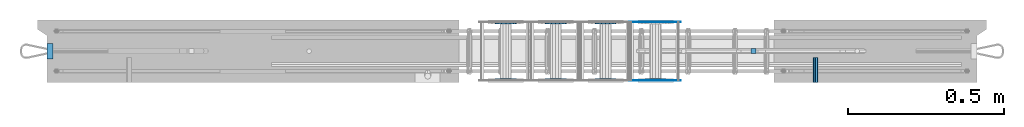
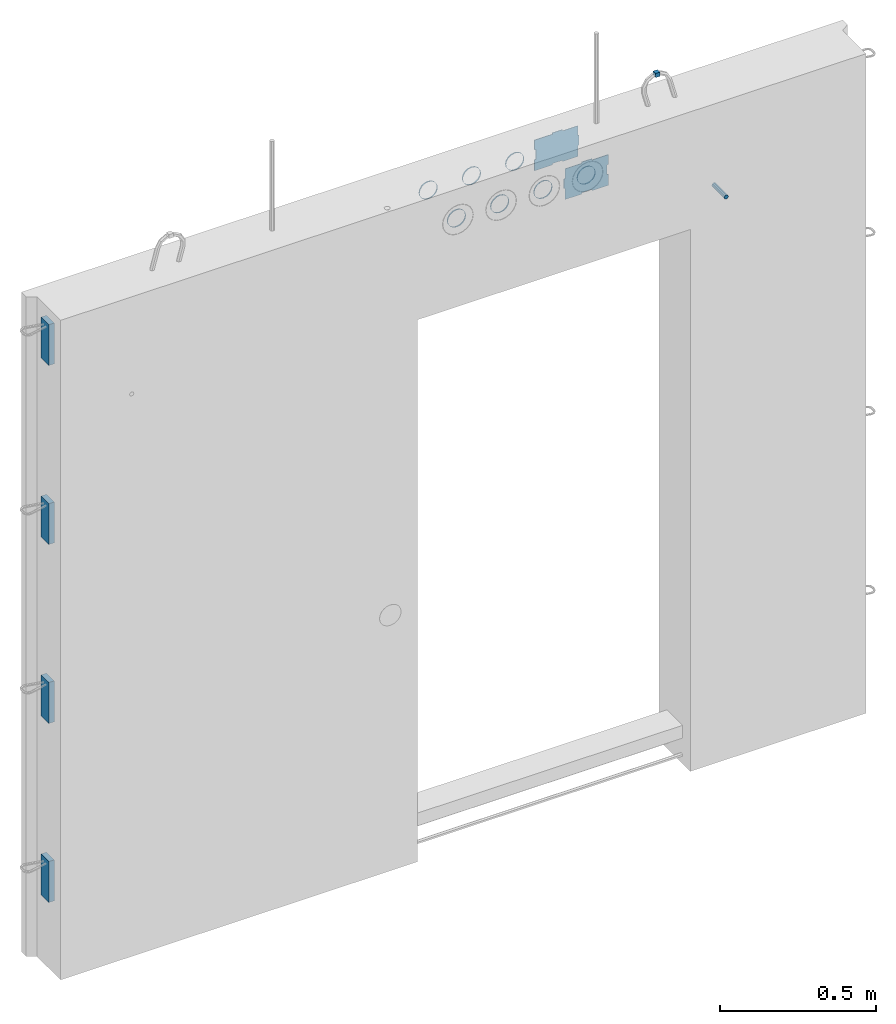
# One storey, part 5 of 11: 9 beams, 6 plates.
"""IFC2X3 building model written with IfcOpenShell, lengths in millimetres."""

from ifc_helpers import new_model, si_unit, frame, origin_with_axes, place, context, subcontext, project, spatial, faceted_brep, material, type_object, element, save


model = new_model("IFC2X3")

# Units and contexts
model_context = context("Model", 3, precision=1e-05, world=origin_with_axes())
body_context = subcontext(model_context, "Body", "Model", "MODEL_VIEW")
ifc_project = project(units=[si_unit("LENGTHUNIT", "METRE", prefix="MILLI"), si_unit("AREAUNIT", "SQUARE_METRE"), si_unit("VOLUMEUNIT", "CUBIC_METRE"), si_unit("MASSUNIT", "GRAM", prefix="KILO"), si_unit("TIMEUNIT", "SECOND"), si_unit("PLANEANGLEUNIT", "RADIAN"), si_unit("SOLIDANGLEUNIT", "STERADIAN"), si_unit("THERMODYNAMICTEMPERATUREUNIT", "DEGREE_CELSIUS"), si_unit("LUMINOUSINTENSITYUNIT", "LUMEN")], contexts=[model_context])

# Site, building, storey
site_placement = place(None, origin_with_axes())
site = spatial("IfcSite", under=ifc_project, at=site_placement, CompositionType="ELEMENT")
building_placement = place(site_placement, origin_with_axes())
building = spatial("IfcBuilding", under=site, at=building_placement, Name="Undefined", CompositionType="ELEMENT")
storey_placement = place(building_placement, origin_with_axes())
storey = spatial("IfcBuildingStorey", under=building, at=storey_placement, Name="Undefined", CompositionType="ELEMENT", Elevation=0.0)

# Beams
ifc_material_1 = material(Name="STEEL/Steel_Undefined")
beam_type_1 = type_object("IfcBeamType", Name="D16", PredefinedType="NOTDEFINED")
beam_1_placement = place(storey_placement, frame((2493.11999948492, -199.99999941953, 2075.00000004103), z_axis=(0.0, 0.0, 1.0), x_axis=(0.0, 1.0, 0.0)))
element("IfcBeam", 1, at=beam_1_placement, inside=storey, type_object=beam_type_1, material=ifc_material_1, Name="M16", ObjectType="D16", context=body_context, shape_type="Brep", body=[
    faceted_brep([(0.0, -8.0, 0.0), (0.0, -5.65685424949238, -5.65685424949243), (79.9999858370938, -5.65685424949243, -5.65685424949243), (79.9999858370938, -8.0, 0.0), (0.0, 0.0, -8.0), (79.9999858370938, 0.0, -8.0), (0.0, 5.65685424949238, -5.65685424949243), (79.9999858370938, 5.65685424949243, -5.65685424949243), (0.0, 8.0, 0.0), (79.9999858370938, 8.0, 0.0), (0.0, 5.65685424949238, 5.65685424949243), (79.9999858370938, 5.65685424949243, 5.65685424949243), (0.0, 0.0, 8.0), (79.9999858370938, 0.0, 8.0), (0.0, -5.65685424949238, 5.65685424949243), (79.9999858370938, -5.65685424949243, 5.65685424949243)], [[[0, 1, 2, 3]], [[1, 4, 5, 2]], [[4, 6, 7, 5]], [[6, 8, 9, 7]], [[8, 10, 11, 9]], [[10, 12, 13, 11]], [[12, 14, 15, 13]], [[14, 0, 3, 15]], [[5, 7, 9, 11, 13, 15, 3, 2]], [[14, 12, 10, 8, 6, 4, 1, 0]]]),
])
beam_type_2 = type_object("IfcBeamType", PredefinedType="NOTDEFINED")
beam_2_placement = place(storey_placement, frame((1979.98457749309, -188.083170120093, 2335.01381840039), z_axis=(-1.0, 0.0, 0.0), x_axis=(0.0, -1.0, 0.0)))
element("IfcBeam", 2, at=beam_2_placement, inside=storey, type_object=beam_type_2, material=ifc_material_1, context=body_context, shape_type="Brep", body=[
    faceted_brep([(0.0, -33.0, 0.0), (0.0, -30.4880245728723, 12.6285532680479), (5.0, -30.4880245728723, 12.6285532680479), (5.0, -33.0, 0.0), (0.0, -23.3345237791559, 23.3345237791561), (5.0, -23.3345237791559, 23.3345237791561), (0.0, -12.6285532680481, 30.4880245728725), (5.0, -12.6285532680481, 30.4880245728725), (0.0, 0.0, 33.0), (5.0, 0.0, 33.0), (0.0, 12.6285532680481, 30.4880245728725), (5.0, 12.6285532680481, 30.4880245728725), (0.0, 23.3345237791559, 23.3345237791561), (5.0, 23.3345237791559, 23.3345237791561), (0.0, 30.4880245728723, 12.6285532680479), (5.0, 30.4880245728723, 12.6285532680479), (0.0, 33.0, 0.0), (5.0, 33.0, 0.0), (0.0, 30.4880245728723, -12.6285532680479), (5.0, 30.4880245728723, -12.6285532680479), (0.0, 23.3345237791559, -23.3345237791561), (5.0, 23.3345237791559, -23.3345237791561), (0.0, 12.6285532680481, -30.4880245728725), (5.0, 12.6285532680481, -30.4880245728725), (0.0, 0.0, -33.0), (5.0, 0.0, -33.0), (0.0, -12.6285532680481, -30.4880245728725), (5.0, -12.6285532680481, -30.4880245728725), (0.0, -23.3345237791559, -23.3345237791561), (5.0, -23.3345237791559, -23.3345237791561), (0.0, -30.4880245728723, -12.6285532680479), (5.0, -30.4880245728723, -12.6285532680479), (0.0, -34.0, 0.0), (0.0, -31.4119041053837, -13.0112367004131), (5.0, -31.4119041053837, -13.0112367004131), (5.0, -34.0, 0.0), (0.0, -24.0416305603426, -24.0416305603426), (5.0, -24.0416305603426, -24.0416305603426), (0.0, -13.0112367004131, -31.4119041053837), (5.0, -13.0112367004131, -31.4119041053837), (0.0, 0.0, -34.0), (5.0, 0.0, -34.0), (0.0, 13.0112367004131, -31.4119041053837), (5.0, 13.0112367004131, -31.4119041053837), (0.0, 24.0416305603426, -24.0416305603426), (5.0, 24.0416305603426, -24.0416305603426), (0.0, 31.4119041053837, -13.0112367004131), (5.0, 31.4119041053837, -13.0112367004131), (0.0, 34.0, 0.0), (5.0, 34.0, 0.0), (0.0, 31.4119041053837, 13.0112367004131), (5.0, 31.4119041053837, 13.0112367004131), (0.0, 24.0416305603426, 24.0416305603426), (5.0, 24.0416305603426, 24.0416305603426), (0.0, 13.0112367004131, 31.4119041053837), (5.0, 13.0112367004131, 31.4119041053837), (0.0, 0.0, 34.0), (5.0, 0.0, 34.0), (0.0, -13.0112367004131, 31.4119041053837), (5.0, -13.0112367004131, 31.4119041053837), (0.0, -24.0416305603426, 24.0416305603426), (5.0, -24.0416305603426, 24.0416305603426), (0.0, -31.4119041053837, 13.0112367004131), (5.0, -31.4119041053837, 13.0112367004131)], [[[0, 1, 2, 3]], [[1, 4, 5, 2]], [[4, 6, 7, 5]], [[6, 8, 9, 7]], [[8, 10, 11, 9]], [[10, 12, 13, 11]], [[12, 14, 15, 13]], [[14, 16, 17, 15]], [[16, 18, 19, 17]], [[18, 20, 21, 19]], [[20, 22, 23, 21]], [[22, 24, 25, 23]], [[24, 26, 27, 25]], [[26, 28, 29, 27]], [[28, 30, 31, 29]], [[30, 0, 3, 31]], [[32, 33, 34, 35]], [[33, 36, 37, 34]], [[36, 38, 39, 37]], [[38, 40, 41, 39]], [[40, 42, 43, 41]], [[42, 44, 45, 43]], [[44, 46, 47, 45]], [[46, 48, 49, 47]], [[48, 50, 51, 49]], [[50, 52, 53, 51]], [[52, 54, 55, 53]], [[54, 56, 57, 55]], [[56, 58, 59, 57]], [[58, 60, 61, 59]], [[60, 62, 63, 61]], [[62, 32, 35, 63]], [[37, 39, 41, 43, 45, 47, 49, 51, 53, 55, 57, 59, 61, 63, 35, 34], [5, 7, 9, 11, 13, 15, 17, 19, 21, 23, 25, 27, 29, 31, 3, 2]], [[62, 60, 58, 56, 54, 52, 50, 48, 46, 44, 42, 40, 38, 36, 33, 32], [30, 28, 26, 24, 22, 20, 18, 16, 14, 12, 10, 8, 6, 4, 1, 0]]]),
])
beam_3_placement = place(storey_placement, frame((1659.98457749309, -12.083170120093, 2335.01381840039), z_axis=(-1.0, 0.0, 0.0), x_axis=(0.0, 1.0, 0.0)))
element("IfcBeam", 3, at=beam_3_placement, inside=storey, type_object=beam_type_2, material=ifc_material_1, context=body_context, shape_type="Brep", body=[
    faceted_brep([(0.0, -33.0, 0.0), (0.0, -30.4880245728723, 12.6285532680479), (5.0, -30.4880245728723, 12.6285532680479), (5.0, -33.0, 0.0), (0.0, -23.3345237791559, 23.3345237791561), (5.0, -23.3345237791559, 23.3345237791561), (0.0, -12.6285532680481, 30.4880245728725), (5.0, -12.6285532680481, 30.4880245728725), (0.0, 0.0, 33.0), (5.0, 0.0, 33.0), (0.0, 12.6285532680481, 30.4880245728725), (5.0, 12.6285532680481, 30.4880245728725), (0.0, 23.3345237791559, 23.3345237791561), (5.0, 23.3345237791559, 23.3345237791561), (0.0, 30.4880245728723, 12.6285532680479), (5.0, 30.4880245728723, 12.6285532680479), (0.0, 33.0, 0.0), (5.0, 33.0, 0.0), (0.0, 30.4880245728723, -12.6285532680479), (5.0, 30.4880245728723, -12.6285532680479), (0.0, 23.3345237791559, -23.3345237791561), (5.0, 23.3345237791559, -23.3345237791561), (0.0, 12.6285532680481, -30.4880245728725), (5.0, 12.6285532680481, -30.4880245728725), (0.0, 0.0, -33.0), (5.0, 0.0, -33.0), (0.0, -12.6285532680481, -30.4880245728725), (5.0, -12.6285532680481, -30.4880245728725), (0.0, -23.3345237791559, -23.3345237791561), (5.0, -23.3345237791559, -23.3345237791561), (0.0, -30.4880245728723, -12.6285532680479), (5.0, -30.4880245728723, -12.6285532680479), (0.0, -34.0, 0.0), (0.0, -31.4119041053837, -13.0112367004131), (5.0, -31.4119041053837, -13.0112367004131), (5.0, -34.0, 0.0), (0.0, -24.0416305603426, -24.0416305603426), (5.0, -24.0416305603426, -24.0416305603426), (0.0, -13.0112367004131, -31.4119041053837), (5.0, -13.0112367004131, -31.4119041053837), (0.0, 0.0, -34.0), (5.0, 0.0, -34.0), (0.0, 13.0112367004131, -31.4119041053837), (5.0, 13.0112367004131, -31.4119041053837), (0.0, 24.0416305603426, -24.0416305603426), (5.0, 24.0416305603426, -24.0416305603426), (0.0, 31.4119041053837, -13.0112367004131), (5.0, 31.4119041053837, -13.0112367004131), (0.0, 34.0, 0.0), (5.0, 34.0, 0.0), (0.0, 31.4119041053837, 13.0112367004131), (5.0, 31.4119041053837, 13.0112367004131), (0.0, 24.0416305603426, 24.0416305603426), (5.0, 24.0416305603426, 24.0416305603426), (0.0, 13.0112367004131, 31.4119041053837), (5.0, 13.0112367004131, 31.4119041053837), (0.0, 0.0, 34.0), (5.0, 0.0, 34.0), (0.0, -13.0112367004131, 31.4119041053837), (5.0, -13.0112367004131, 31.4119041053837), (0.0, -24.0416305603426, 24.0416305603426), (5.0, -24.0416305603426, 24.0416305603426), (0.0, -31.4119041053837, 13.0112367004131), (5.0, -31.4119041053837, 13.0112367004131)], [[[0, 1, 2, 3]], [[1, 4, 5, 2]], [[4, 6, 7, 5]], [[6, 8, 9, 7]], [[8, 10, 11, 9]], [[10, 12, 13, 11]], [[12, 14, 15, 13]], [[14, 16, 17, 15]], [[16, 18, 19, 17]], [[18, 20, 21, 19]], [[20, 22, 23, 21]], [[22, 24, 25, 23]], [[24, 26, 27, 25]], [[26, 28, 29, 27]], [[28, 30, 31, 29]], [[30, 0, 3, 31]], [[32, 33, 34, 35]], [[33, 36, 37, 34]], [[36, 38, 39, 37]], [[38, 40, 41, 39]], [[40, 42, 43, 41]], [[42, 44, 45, 43]], [[44, 46, 47, 45]], [[46, 48, 49, 47]], [[48, 50, 51, 49]], [[50, 52, 53, 51]], [[52, 54, 55, 53]], [[54, 56, 57, 55]], [[56, 58, 59, 57]], [[58, 60, 61, 59]], [[60, 62, 63, 61]], [[62, 32, 35, 63]], [[37, 39, 41, 43, 45, 47, 49, 51, 53, 55, 57, 59, 61, 63, 35, 34], [5, 7, 9, 11, 13, 15, 17, 19, 21, 23, 25, 27, 29, 31, 3, 2]], [[62, 60, 58, 56, 54, 52, 50, 48, 46, 44, 42, 40, 38, 36, 33, 32], [30, 28, 26, 24, 22, 20, 18, 16, 14, 12, 10, 8, 6, 4, 1, 0]]]),
])
beam_4_placement = place(storey_placement, frame((1659.98457749309, -188.083170120093, 2335.01381840039), z_axis=(-1.0, 0.0, 0.0), x_axis=(0.0, -1.0, 0.0)))
element("IfcBeam", 4, at=beam_4_placement, inside=storey, type_object=beam_type_2, material=ifc_material_1, context=body_context, shape_type="Brep", body=[
    faceted_brep([(0.0, -33.0, 0.0), (0.0, -30.4880245728723, 12.6285532680479), (5.0, -30.4880245728723, 12.6285532680479), (5.0, -33.0, 0.0), (0.0, -23.3345237791559, 23.3345237791561), (5.0, -23.3345237791559, 23.3345237791561), (0.0, -12.6285532680481, 30.4880245728725), (5.0, -12.6285532680481, 30.4880245728725), (0.0, 0.0, 33.0), (5.0, 0.0, 33.0), (0.0, 12.6285532680481, 30.4880245728725), (5.0, 12.6285532680481, 30.4880245728725), (0.0, 23.3345237791559, 23.3345237791561), (5.0, 23.3345237791559, 23.3345237791561), (0.0, 30.4880245728723, 12.6285532680479), (5.0, 30.4880245728723, 12.6285532680479), (0.0, 33.0, 0.0), (5.0, 33.0, 0.0), (0.0, 30.4880245728723, -12.6285532680479), (5.0, 30.4880245728723, -12.6285532680479), (0.0, 23.3345237791559, -23.3345237791561), (5.0, 23.3345237791559, -23.3345237791561), (0.0, 12.6285532680481, -30.4880245728725), (5.0, 12.6285532680481, -30.4880245728725), (0.0, 0.0, -33.0), (5.0, 0.0, -33.0), (0.0, -12.6285532680481, -30.4880245728725), (5.0, -12.6285532680481, -30.4880245728725), (0.0, -23.3345237791559, -23.3345237791561), (5.0, -23.3345237791559, -23.3345237791561), (0.0, -30.4880245728723, -12.6285532680479), (5.0, -30.4880245728723, -12.6285532680479), (0.0, -34.0, 0.0), (0.0, -31.4119041053837, -13.0112367004131), (5.0, -31.4119041053837, -13.0112367004131), (5.0, -34.0, 0.0), (0.0, -24.0416305603426, -24.0416305603426), (5.0, -24.0416305603426, -24.0416305603426), (0.0, -13.0112367004131, -31.4119041053837), (5.0, -13.0112367004131, -31.4119041053837), (0.0, 0.0, -34.0), (5.0, 0.0, -34.0), (0.0, 13.0112367004131, -31.4119041053837), (5.0, 13.0112367004131, -31.4119041053837), (0.0, 24.0416305603426, -24.0416305603426), (5.0, 24.0416305603426, -24.0416305603426), (0.0, 31.4119041053837, -13.0112367004131), (5.0, 31.4119041053837, -13.0112367004131), (0.0, 34.0, 0.0), (5.0, 34.0, 0.0), (0.0, 31.4119041053837, 13.0112367004131), (5.0, 31.4119041053837, 13.0112367004131), (0.0, 24.0416305603426, 24.0416305603426), (5.0, 24.0416305603426, 24.0416305603426), (0.0, 13.0112367004131, 31.4119041053837), (5.0, 13.0112367004131, 31.4119041053837), (0.0, 0.0, 34.0), (5.0, 0.0, 34.0), (0.0, -13.0112367004131, 31.4119041053837), (5.0, -13.0112367004131, 31.4119041053837), (0.0, -24.0416305603426, 24.0416305603426), (5.0, -24.0416305603426, 24.0416305603426), (0.0, -31.4119041053837, 13.0112367004131), (5.0, -31.4119041053837, 13.0112367004131)], [[[0, 1, 2, 3]], [[1, 4, 5, 2]], [[4, 6, 7, 5]], [[6, 8, 9, 7]], [[8, 10, 11, 9]], [[10, 12, 13, 11]], [[12, 14, 15, 13]], [[14, 16, 17, 15]], [[16, 18, 19, 17]], [[18, 20, 21, 19]], [[20, 22, 23, 21]], [[22, 24, 25, 23]], [[24, 26, 27, 25]], [[26, 28, 29, 27]], [[28, 30, 31, 29]], [[30, 0, 3, 31]], [[32, 33, 34, 35]], [[33, 36, 37, 34]], [[36, 38, 39, 37]], [[38, 40, 41, 39]], [[40, 42, 43, 41]], [[42, 44, 45, 43]], [[44, 46, 47, 45]], [[46, 48, 49, 47]], [[48, 50, 51, 49]], [[50, 52, 53, 51]], [[52, 54, 55, 53]], [[54, 56, 57, 55]], [[56, 58, 59, 57]], [[58, 60, 61, 59]], [[60, 62, 63, 61]], [[62, 32, 35, 63]], [[37, 39, 41, 43, 45, 47, 49, 51, 53, 55, 57, 59, 61, 63, 35, 34], [5, 7, 9, 11, 13, 15, 17, 19, 21, 23, 25, 27, 29, 31, 3, 2]], [[62, 60, 58, 56, 54, 52, 50, 48, 46, 44, 42, 40, 38, 36, 33, 32], [30, 28, 26, 24, 22, 20, 18, 16, 14, 12, 10, 8, 6, 4, 1, 0]]]),
])
beam_5_placement = place(storey_placement, frame((1819.98457749309, -12.083170120093, 2335.01381840039), z_axis=(-1.0, 0.0, 0.0), x_axis=(0.0, 1.0, 0.0)))
element("IfcBeam", 5, at=beam_5_placement, inside=storey, type_object=beam_type_2, material=ifc_material_1, context=body_context, shape_type="Brep", body=[
    faceted_brep([(0.0, -33.0, 0.0), (0.0, -30.4880245728723, 12.6285532680479), (5.0, -30.4880245728723, 12.6285532680479), (5.0, -33.0, 0.0), (0.0, -23.3345237791559, 23.3345237791561), (5.0, -23.3345237791559, 23.3345237791561), (0.0, -12.6285532680481, 30.4880245728725), (5.0, -12.6285532680481, 30.4880245728725), (0.0, 0.0, 33.0), (5.0, 0.0, 33.0), (0.0, 12.6285532680481, 30.4880245728725), (5.0, 12.6285532680481, 30.4880245728725), (0.0, 23.3345237791559, 23.3345237791561), (5.0, 23.3345237791559, 23.3345237791561), (0.0, 30.4880245728723, 12.6285532680479), (5.0, 30.4880245728723, 12.6285532680479), (0.0, 33.0, 0.0), (5.0, 33.0, 0.0), (0.0, 30.4880245728723, -12.6285532680479), (5.0, 30.4880245728723, -12.6285532680479), (0.0, 23.3345237791559, -23.3345237791561), (5.0, 23.3345237791559, -23.3345237791561), (0.0, 12.6285532680481, -30.4880245728725), (5.0, 12.6285532680481, -30.4880245728725), (0.0, 0.0, -33.0), (5.0, 0.0, -33.0), (0.0, -12.6285532680481, -30.4880245728725), (5.0, -12.6285532680481, -30.4880245728725), (0.0, -23.3345237791559, -23.3345237791561), (5.0, -23.3345237791559, -23.3345237791561), (0.0, -30.4880245728723, -12.6285532680479), (5.0, -30.4880245728723, -12.6285532680479), (0.0, -34.0, 0.0), (0.0, -31.4119041053837, -13.0112367004131), (5.0, -31.4119041053837, -13.0112367004131), (5.0, -34.0, 0.0), (0.0, -24.0416305603426, -24.0416305603426), (5.0, -24.0416305603426, -24.0416305603426), (0.0, -13.0112367004131, -31.4119041053837), (5.0, -13.0112367004131, -31.4119041053837), (0.0, 0.0, -34.0), (5.0, 0.0, -34.0), (0.0, 13.0112367004131, -31.4119041053837), (5.0, 13.0112367004131, -31.4119041053837), (0.0, 24.0416305603426, -24.0416305603426), (5.0, 24.0416305603426, -24.0416305603426), (0.0, 31.4119041053837, -13.0112367004131), (5.0, 31.4119041053837, -13.0112367004131), (0.0, 34.0, 0.0), (5.0, 34.0, 0.0), (0.0, 31.4119041053837, 13.0112367004131), (5.0, 31.4119041053837, 13.0112367004131), (0.0, 24.0416305603426, 24.0416305603426), (5.0, 24.0416305603426, 24.0416305603426), (0.0, 13.0112367004131, 31.4119041053837), (5.0, 13.0112367004131, 31.4119041053837), (0.0, 0.0, 34.0), (5.0, 0.0, 34.0), (0.0, -13.0112367004131, 31.4119041053837), (5.0, -13.0112367004131, 31.4119041053837), (0.0, -24.0416305603426, 24.0416305603426), (5.0, -24.0416305603426, 24.0416305603426), (0.0, -31.4119041053837, 13.0112367004131), (5.0, -31.4119041053837, 13.0112367004131)], [[[0, 1, 2, 3]], [[1, 4, 5, 2]], [[4, 6, 7, 5]], [[6, 8, 9, 7]], [[8, 10, 11, 9]], [[10, 12, 13, 11]], [[12, 14, 15, 13]], [[14, 16, 17, 15]], [[16, 18, 19, 17]], [[18, 20, 21, 19]], [[20, 22, 23, 21]], [[22, 24, 25, 23]], [[24, 26, 27, 25]], [[26, 28, 29, 27]], [[28, 30, 31, 29]], [[30, 0, 3, 31]], [[32, 33, 34, 35]], [[33, 36, 37, 34]], [[36, 38, 39, 37]], [[38, 40, 41, 39]], [[40, 42, 43, 41]], [[42, 44, 45, 43]], [[44, 46, 47, 45]], [[46, 48, 49, 47]], [[48, 50, 51, 49]], [[50, 52, 53, 51]], [[52, 54, 55, 53]], [[54, 56, 57, 55]], [[56, 58, 59, 57]], [[58, 60, 61, 59]], [[60, 62, 63, 61]], [[62, 32, 35, 63]], [[37, 39, 41, 43, 45, 47, 49, 51, 53, 55, 57, 59, 61, 63, 35, 34], [5, 7, 9, 11, 13, 15, 17, 19, 21, 23, 25, 27, 29, 31, 3, 2]], [[62, 60, 58, 56, 54, 52, 50, 48, 46, 44, 42, 40, 38, 36, 33, 32], [30, 28, 26, 24, 22, 20, 18, 16, 14, 12, 10, 8, 6, 4, 1, 0]]]),
])
beam_6_placement = place(storey_placement, frame((1819.98457749309, -188.083170120093, 2335.01381840039), z_axis=(-1.0, 0.0, 0.0), x_axis=(0.0, -1.0, 0.0)))
element("IfcBeam", 6, at=beam_6_placement, inside=storey, type_object=beam_type_2, material=ifc_material_1, context=body_context, shape_type="Brep", body=[
    faceted_brep([(0.0, -33.0, 0.0), (0.0, -30.4880245728723, 12.6285532680479), (5.0, -30.4880245728723, 12.6285532680479), (5.0, -33.0, 0.0), (0.0, -23.3345237791559, 23.3345237791561), (5.0, -23.3345237791559, 23.3345237791561), (0.0, -12.6285532680481, 30.4880245728725), (5.0, -12.6285532680481, 30.4880245728725), (0.0, 0.0, 33.0), (5.0, 0.0, 33.0), (0.0, 12.6285532680481, 30.4880245728725), (5.0, 12.6285532680481, 30.4880245728725), (0.0, 23.3345237791559, 23.3345237791561), (5.0, 23.3345237791559, 23.3345237791561), (0.0, 30.4880245728723, 12.6285532680479), (5.0, 30.4880245728723, 12.6285532680479), (0.0, 33.0, 0.0), (5.0, 33.0, 0.0), (0.0, 30.4880245728723, -12.6285532680479), (5.0, 30.4880245728723, -12.6285532680479), (0.0, 23.3345237791559, -23.3345237791561), (5.0, 23.3345237791559, -23.3345237791561), (0.0, 12.6285532680481, -30.4880245728725), (5.0, 12.6285532680481, -30.4880245728725), (0.0, 0.0, -33.0), (5.0, 0.0, -33.0), (0.0, -12.6285532680481, -30.4880245728725), (5.0, -12.6285532680481, -30.4880245728725), (0.0, -23.3345237791559, -23.3345237791561), (5.0, -23.3345237791559, -23.3345237791561), (0.0, -30.4880245728723, -12.6285532680479), (5.0, -30.4880245728723, -12.6285532680479), (0.0, -34.0, 0.0), (0.0, -31.4119041053837, -13.0112367004131), (5.0, -31.4119041053837, -13.0112367004131), (5.0, -34.0, 0.0), (0.0, -24.0416305603426, -24.0416305603426), (5.0, -24.0416305603426, -24.0416305603426), (0.0, -13.0112367004131, -31.4119041053837), (5.0, -13.0112367004131, -31.4119041053837), (0.0, 0.0, -34.0), (5.0, 0.0, -34.0), (0.0, 13.0112367004131, -31.4119041053837), (5.0, 13.0112367004131, -31.4119041053837), (0.0, 24.0416305603426, -24.0416305603426), (5.0, 24.0416305603426, -24.0416305603426), (0.0, 31.4119041053837, -13.0112367004131), (5.0, 31.4119041053837, -13.0112367004131), (0.0, 34.0, 0.0), (5.0, 34.0, 0.0), (0.0, 31.4119041053837, 13.0112367004131), (5.0, 31.4119041053837, 13.0112367004131), (0.0, 24.0416305603426, 24.0416305603426), (5.0, 24.0416305603426, 24.0416305603426), (0.0, 13.0112367004131, 31.4119041053837), (5.0, 13.0112367004131, 31.4119041053837), (0.0, 0.0, 34.0), (5.0, 0.0, 34.0), (0.0, -13.0112367004131, 31.4119041053837), (5.0, -13.0112367004131, 31.4119041053837), (0.0, -24.0416305603426, 24.0416305603426), (5.0, -24.0416305603426, 24.0416305603426), (0.0, -31.4119041053837, 13.0112367004131), (5.0, -31.4119041053837, 13.0112367004131)], [[[0, 1, 2, 3]], [[1, 4, 5, 2]], [[4, 6, 7, 5]], [[6, 8, 9, 7]], [[8, 10, 11, 9]], [[10, 12, 13, 11]], [[12, 14, 15, 13]], [[14, 16, 17, 15]], [[16, 18, 19, 17]], [[18, 20, 21, 19]], [[20, 22, 23, 21]], [[22, 24, 25, 23]], [[24, 26, 27, 25]], [[26, 28, 29, 27]], [[28, 30, 31, 29]], [[30, 0, 3, 31]], [[32, 33, 34, 35]], [[33, 36, 37, 34]], [[36, 38, 39, 37]], [[38, 40, 41, 39]], [[40, 42, 43, 41]], [[42, 44, 45, 43]], [[44, 46, 47, 45]], [[46, 48, 49, 47]], [[48, 50, 51, 49]], [[50, 52, 53, 51]], [[52, 54, 55, 53]], [[54, 56, 57, 55]], [[56, 58, 59, 57]], [[58, 60, 61, 59]], [[60, 62, 63, 61]], [[62, 32, 35, 63]], [[37, 39, 41, 43, 45, 47, 49, 51, 53, 55, 57, 59, 61, 63, 35, 34], [5, 7, 9, 11, 13, 15, 17, 19, 21, 23, 25, 27, 29, 31, 3, 2]], [[62, 60, 58, 56, 54, 52, 50, 48, 46, 44, 42, 40, 38, 36, 33, 32], [30, 28, 26, 24, 22, 20, 18, 16, 14, 12, 10, 8, 6, 4, 1, 0]]]),
])
beam_7_placement = place(storey_placement, frame((1499.98457749309, -12.083170120093, 2335.01381840039), z_axis=(-1.0, 0.0, 0.0), x_axis=(0.0, 1.0, 0.0)))
element("IfcBeam", 7, at=beam_7_placement, inside=storey, type_object=beam_type_2, material=ifc_material_1, context=body_context, shape_type="Brep", body=[
    faceted_brep([(0.0, -33.0, 0.0), (0.0, -30.4880245728723, 12.6285532680479), (5.0, -30.4880245728723, 12.6285532680479), (5.0, -33.0, 0.0), (0.0, -23.3345237791559, 23.3345237791561), (5.0, -23.3345237791559, 23.3345237791561), (0.0, -12.6285532680481, 30.4880245728725), (5.0, -12.6285532680481, 30.4880245728725), (0.0, 0.0, 33.0), (5.0, 0.0, 33.0), (0.0, 12.6285532680481, 30.4880245728725), (5.0, 12.6285532680481, 30.4880245728725), (0.0, 23.3345237791559, 23.3345237791561), (5.0, 23.3345237791559, 23.3345237791561), (0.0, 30.4880245728723, 12.6285532680479), (5.0, 30.4880245728723, 12.6285532680479), (0.0, 33.0, 0.0), (5.0, 33.0, 0.0), (0.0, 30.4880245728723, -12.6285532680479), (5.0, 30.4880245728723, -12.6285532680479), (0.0, 23.3345237791559, -23.3345237791561), (5.0, 23.3345237791559, -23.3345237791561), (0.0, 12.6285532680481, -30.4880245728725), (5.0, 12.6285532680481, -30.4880245728725), (0.0, 0.0, -33.0), (5.0, 0.0, -33.0), (0.0, -12.6285532680481, -30.4880245728725), (5.0, -12.6285532680481, -30.4880245728725), (0.0, -23.3345237791559, -23.3345237791561), (5.0, -23.3345237791559, -23.3345237791561), (0.0, -30.4880245728723, -12.6285532680479), (5.0, -30.4880245728723, -12.6285532680479), (0.0, -34.0, 0.0), (0.0, -31.4119041053837, -13.0112367004131), (5.0, -31.4119041053837, -13.0112367004131), (5.0, -34.0, 0.0), (0.0, -24.0416305603426, -24.0416305603426), (5.0, -24.0416305603426, -24.0416305603426), (0.0, -13.0112367004131, -31.4119041053837), (5.0, -13.0112367004131, -31.4119041053837), (0.0, 0.0, -34.0), (5.0, 0.0, -34.0), (0.0, 13.0112367004131, -31.4119041053837), (5.0, 13.0112367004131, -31.4119041053837), (0.0, 24.0416305603426, -24.0416305603426), (5.0, 24.0416305603426, -24.0416305603426), (0.0, 31.4119041053837, -13.0112367004131), (5.0, 31.4119041053837, -13.0112367004131), (0.0, 34.0, 0.0), (5.0, 34.0, 0.0), (0.0, 31.4119041053837, 13.0112367004131), (5.0, 31.4119041053837, 13.0112367004131), (0.0, 24.0416305603426, 24.0416305603426), (5.0, 24.0416305603426, 24.0416305603426), (0.0, 13.0112367004131, 31.4119041053837), (5.0, 13.0112367004131, 31.4119041053837), (0.0, 0.0, 34.0), (5.0, 0.0, 34.0), (0.0, -13.0112367004131, 31.4119041053837), (5.0, -13.0112367004131, 31.4119041053837), (0.0, -24.0416305603426, 24.0416305603426), (5.0, -24.0416305603426, 24.0416305603426), (0.0, -31.4119041053837, 13.0112367004131), (5.0, -31.4119041053837, 13.0112367004131)], [[[0, 1, 2, 3]], [[1, 4, 5, 2]], [[4, 6, 7, 5]], [[6, 8, 9, 7]], [[8, 10, 11, 9]], [[10, 12, 13, 11]], [[12, 14, 15, 13]], [[14, 16, 17, 15]], [[16, 18, 19, 17]], [[18, 20, 21, 19]], [[20, 22, 23, 21]], [[22, 24, 25, 23]], [[24, 26, 27, 25]], [[26, 28, 29, 27]], [[28, 30, 31, 29]], [[30, 0, 3, 31]], [[32, 33, 34, 35]], [[33, 36, 37, 34]], [[36, 38, 39, 37]], [[38, 40, 41, 39]], [[40, 42, 43, 41]], [[42, 44, 45, 43]], [[44, 46, 47, 45]], [[46, 48, 49, 47]], [[48, 50, 51, 49]], [[50, 52, 53, 51]], [[52, 54, 55, 53]], [[54, 56, 57, 55]], [[56, 58, 59, 57]], [[58, 60, 61, 59]], [[60, 62, 63, 61]], [[62, 32, 35, 63]], [[37, 39, 41, 43, 45, 47, 49, 51, 53, 55, 57, 59, 61, 63, 35, 34], [5, 7, 9, 11, 13, 15, 17, 19, 21, 23, 25, 27, 29, 31, 3, 2]], [[62, 60, 58, 56, 54, 52, 50, 48, 46, 44, 42, 40, 38, 36, 33, 32], [30, 28, 26, 24, 22, 20, 18, 16, 14, 12, 10, 8, 6, 4, 1, 0]]]),
])
beam_8_placement = place(storey_placement, frame((1499.98457749309, -188.083170120093, 2335.01381840039), z_axis=(-1.0, 0.0, 0.0), x_axis=(0.0, -1.0, 0.0)))
element("IfcBeam", 8, at=beam_8_placement, inside=storey, type_object=beam_type_2, material=ifc_material_1, context=body_context, shape_type="Brep", body=[
    faceted_brep([(0.0, -33.0, 0.0), (0.0, -30.4880245728723, 12.6285532680479), (5.0, -30.4880245728723, 12.6285532680479), (5.0, -33.0, 0.0), (0.0, -23.3345237791559, 23.3345237791561), (5.0, -23.3345237791559, 23.3345237791561), (0.0, -12.6285532680481, 30.4880245728725), (5.0, -12.6285532680481, 30.4880245728725), (0.0, 0.0, 33.0), (5.0, 0.0, 33.0), (0.0, 12.6285532680481, 30.4880245728725), (5.0, 12.6285532680481, 30.4880245728725), (0.0, 23.3345237791559, 23.3345237791561), (5.0, 23.3345237791559, 23.3345237791561), (0.0, 30.4880245728723, 12.6285532680479), (5.0, 30.4880245728723, 12.6285532680479), (0.0, 33.0, 0.0), (5.0, 33.0, 0.0), (0.0, 30.4880245728723, -12.6285532680479), (5.0, 30.4880245728723, -12.6285532680479), (0.0, 23.3345237791559, -23.3345237791561), (5.0, 23.3345237791559, -23.3345237791561), (0.0, 12.6285532680481, -30.4880245728725), (5.0, 12.6285532680481, -30.4880245728725), (0.0, 0.0, -33.0), (5.0, 0.0, -33.0), (0.0, -12.6285532680481, -30.4880245728725), (5.0, -12.6285532680481, -30.4880245728725), (0.0, -23.3345237791559, -23.3345237791561), (5.0, -23.3345237791559, -23.3345237791561), (0.0, -30.4880245728723, -12.6285532680479), (5.0, -30.4880245728723, -12.6285532680479), (0.0, -34.0, 0.0), (0.0, -31.4119041053837, -13.0112367004131), (5.0, -31.4119041053837, -13.0112367004131), (5.0, -34.0, 0.0), (0.0, -24.0416305603426, -24.0416305603426), (5.0, -24.0416305603426, -24.0416305603426), (0.0, -13.0112367004131, -31.4119041053837), (5.0, -13.0112367004131, -31.4119041053837), (0.0, 0.0, -34.0), (5.0, 0.0, -34.0), (0.0, 13.0112367004131, -31.4119041053837), (5.0, 13.0112367004131, -31.4119041053837), (0.0, 24.0416305603426, -24.0416305603426), (5.0, 24.0416305603426, -24.0416305603426), (0.0, 31.4119041053837, -13.0112367004131), (5.0, 31.4119041053837, -13.0112367004131), (0.0, 34.0, 0.0), (5.0, 34.0, 0.0), (0.0, 31.4119041053837, 13.0112367004131), (5.0, 31.4119041053837, 13.0112367004131), (0.0, 24.0416305603426, 24.0416305603426), (5.0, 24.0416305603426, 24.0416305603426), (0.0, 13.0112367004131, 31.4119041053837), (5.0, 13.0112367004131, 31.4119041053837), (0.0, 0.0, 34.0), (5.0, 0.0, 34.0), (0.0, -13.0112367004131, 31.4119041053837), (5.0, -13.0112367004131, 31.4119041053837), (0.0, -24.0416305603426, 24.0416305603426), (5.0, -24.0416305603426, 24.0416305603426), (0.0, -31.4119041053837, 13.0112367004131), (5.0, -31.4119041053837, 13.0112367004131)], [[[0, 1, 2, 3]], [[1, 4, 5, 2]], [[4, 6, 7, 5]], [[6, 8, 9, 7]], [[8, 10, 11, 9]], [[10, 12, 13, 11]], [[12, 14, 15, 13]], [[14, 16, 17, 15]], [[16, 18, 19, 17]], [[18, 20, 21, 19]], [[20, 22, 23, 21]], [[22, 24, 25, 23]], [[24, 26, 27, 25]], [[26, 28, 29, 27]], [[28, 30, 31, 29]], [[30, 0, 3, 31]], [[32, 33, 34, 35]], [[33, 36, 37, 34]], [[36, 38, 39, 37]], [[38, 40, 41, 39]], [[40, 42, 43, 41]], [[42, 44, 45, 43]], [[44, 46, 47, 45]], [[46, 48, 49, 47]], [[48, 50, 51, 49]], [[50, 52, 53, 51]], [[52, 54, 55, 53]], [[54, 56, 57, 55]], [[56, 58, 59, 57]], [[58, 60, 61, 59]], [[60, 62, 63, 61]], [[62, 32, 35, 63]], [[37, 39, 41, 43, 45, 47, 49, 51, 53, 55, 57, 59, 61, 63, 35, 34], [5, 7, 9, 11, 13, 15, 17, 19, 21, 23, 25, 27, 29, 31, 3, 2]], [[62, 60, 58, 56, 54, 52, 50, 48, 46, 44, 42, 40, 38, 36, 33, 32], [30, 28, 26, 24, 22, 20, 18, 16, 14, 12, 10, 8, 6, 4, 1, 0]]]),
])
ifc_material_2 = material()
beam_type_3 = type_object("IfcBeamType", PredefinedType="NOTDEFINED")
beam_9_placement = place(storey_placement, frame((2301.12776118523, -99.5664404567494, 2567.00000004103), z_axis=(0.0, 0.0, 1.0), x_axis=(-1.0, 0.0, 0.0)))
element("IfcBeam", 9, at=beam_9_placement, inside=storey, type_object=beam_type_3, material=ifc_material_2, context=body_context, shape_type="Brep", body=[
    faceted_brep([(0.0, 8.0, -8.0), (0.0, 8.0, 8.0), (16.0, 8.0, 8.0), (16.0, 8.0, -8.0), (0.0, -8.0, 8.0), (16.0, -8.0, 8.0), (0.0, -8.0, -8.0), (16.0, -8.0, -8.0)], [[[0, 1, 2, 3]], [[1, 4, 5, 2]], [[4, 6, 7, 5]], [[6, 0, 3, 7]], [[5, 7, 3, 2]], [[6, 4, 1, 0]]]),
])

# Plates
plate_type_1 = type_object("IfcPlateType", PredefinedType="NOTDEFINED")
for number, where, z_axis, x_axis, name in (
    (10, (49.999992503653, -125.000000416568, 212.500000041032), (-1.0, 0.0, 0.0), (0.0, 1.0, 0.0), "VL80"),
    (11, (49.999995000038, -124.999998419464, 912.500000041033), (-1.0, 0.0, 0.0), (0.0, 1.0, 0.0), "VL80"),
    (12, (49.9999950000386, -124.999998419471, 1612.50000004103), (-1.0, 0.0, 0.0), (0.0, 1.0, 0.0), "VL80"),
    (13, (49.9999950000392, -124.999998419471, 2312.50000004103), (-1.0, 0.0, 0.0), (0.0, 1.0, 0.0), "VL80"),
):
    element("IfcPlate", number, at=place(storey_placement, frame(where, z_axis=z_axis, x_axis=x_axis)), inside=storey, type_object=plate_type_1, material=ifc_material_1, Name=name, context=body_context, shape_type="Brep", body=[
        faceted_brep([(-1.4210854715202e-14, -80.0, -7.105427357601e-15), (-1.4210854715202e-14, -80.0, 20.0), (-1.4210854715202e-14, 80.0, 20.0), (-1.4210854715202e-14, 80.0, -7.105427357601e-15), (50.0, -80.0, 20.0), (50.0, 80.0, 20.0), (50.0, -80.0, -7.105427357601e-15), (50.0, 80.0, -7.105427357601e-15)], [[[0, 1, 2, 3]], [[1, 4, 5, 2]], [[4, 6, 7, 5]], [[6, 0, 3, 7]], [[5, 7, 3, 2]], [[6, 4, 1, 0]]]),
    ])
plate_type_2 = type_object("IfcPlateType", PredefinedType="NOTDEFINED")
plate_1_placement = place(storey_placement, frame((2054.98457749309, -6.08317012009296, 2270.0138184004), z_axis=(0.0, 0.0, 1.0), x_axis=(-1.0, 0.0, 0.0)))
element("IfcPlate", 14, at=plate_1_placement, inside=storey, type_object=plate_type_2, material=ifc_material_1, context=body_context, shape_type="Brep", body=[
    faceted_brep([(0.0, -1.0, 0.0), (0.0, -1.0, 43.0), (0.0, 1.0, 43.0), (0.0, 1.0, 0.0), (-5.0, -1.0, 44.0), (-5.0, 1.0, 44.0), (-5.0, -1.0, 81.0), (-5.0, 1.0, 81.0), (0.0, -1.0, 82.0), (0.0, 1.0, 82.0), (0.0, -1.0, 120.0), (0.0, 1.0, 120.0), (55.5, -1.0, 120.0), (55.5, 1.0, 120.0), (56.5, -1.0, 125.0), (56.5, 1.0, 125.0), (93.5, -1.0, 125.0), (93.5, 1.0, 125.0), (94.5, -1.0, 120.0), (94.5, 1.0, 120.0), (160.0, -1.0, 120.0), (160.0, 1.0, 120.0), (160.0, -1.0, 82.0), (160.0, 1.0, 82.0), (155.0, -1.0, 81.0), (155.0, 1.0, 81.0), (155.0, -1.0, 44.0), (155.0, 1.0, 44.0), (160.0, -1.0, 43.0), (160.0, 1.0, 43.0), (160.0, -1.0, -2.72848410531878e-12), (160.0, 1.0, -2.72848410531878e-12), (94.5, -1.0, 0.0), (94.5, 1.0, 0.0), (93.5, -1.0, 5.0), (93.5, 1.0, 5.0), (56.5, -1.0, 5.0), (56.5, 1.0, 5.0), (55.5, -1.0, 0.0), (55.5, 1.0, 0.0)], [[[0, 1, 2, 3]], [[1, 4, 5, 2]], [[4, 6, 7, 5]], [[6, 8, 9, 7]], [[8, 10, 11, 9]], [[10, 12, 13, 11]], [[12, 14, 15, 13]], [[14, 16, 17, 15]], [[16, 18, 19, 17]], [[18, 20, 21, 19]], [[20, 22, 23, 21]], [[22, 24, 25, 23]], [[24, 26, 27, 25]], [[26, 28, 29, 27]], [[28, 30, 31, 29]], [[30, 32, 33, 31]], [[32, 34, 35, 33]], [[34, 36, 37, 35]], [[36, 38, 39, 37]], [[38, 0, 3, 39]], [[5, 7, 9, 11, 13, 15, 17, 19, 21, 23, 25, 27, 29, 31, 33, 35, 37, 39, 3, 2]], [[38, 36, 34, 32, 30, 28, 26, 24, 22, 20, 18, 16, 14, 12, 10, 8, 6, 4, 1, 0]]]),
])
plate_2_placement = place(storey_placement, frame((2059.98457749309, -194.083170120093, 2270.0138184004), z_axis=(0.0, 0.0, 1.0), x_axis=(-1.0, 0.0, 0.0)))
element("IfcPlate", 15, at=plate_2_placement, inside=storey, type_object=plate_type_2, material=ifc_material_1, context=body_context, shape_type="Brep", body=[
    faceted_brep([(0.0, -1.0, 0.0), (0.0, -1.0, 43.0), (0.0, 1.0, 43.0), (0.0, 1.0, 0.0), (5.0, -1.0, 44.0), (5.0, 1.0, 44.0), (5.0, -1.0, 81.0), (5.0, 1.0, 81.0), (0.0, -1.0, 82.0), (0.0, 1.0, 82.0), (0.0, -1.0, 120.0), (0.0, 1.0, 120.0), (60.5, -1.0, 120.0), (60.5, 1.0, 120.0), (61.5, -1.0, 125.0), (61.5, 1.0, 125.0), (98.5, -1.0, 125.0), (98.5, 1.0, 125.0), (99.5, -1.0, 120.0), (99.5, 1.0, 120.0), (160.0, -1.0, 120.0), (160.0, 1.0, 120.0), (160.0, -1.0, 82.0), (160.0, 1.0, 82.0), (165.0, -1.0, 81.0), (165.0, 1.0, 81.0), (165.0, -1.0, 44.0), (165.0, 1.0, 44.0), (160.0, -1.0, 43.0), (160.0, 1.0, 43.0), (160.0, -1.0, -2.72848410531878e-12), (160.0, 1.0, -2.72848410531878e-12), (99.5, -1.0, 0.0), (99.5, 1.0, 0.0), (98.5, -1.0, 5.0), (98.5, 1.0, 5.0), (61.5, -1.0, 5.0), (61.5, 1.0, 5.0), (60.5, -1.0, 0.0), (60.5, 1.0, 0.0)], [[[0, 1, 2, 3]], [[1, 4, 5, 2]], [[4, 6, 7, 5]], [[6, 8, 9, 7]], [[8, 10, 11, 9]], [[10, 12, 13, 11]], [[12, 14, 15, 13]], [[14, 16, 17, 15]], [[16, 18, 19, 17]], [[18, 20, 21, 19]], [[20, 22, 23, 21]], [[22, 24, 25, 23]], [[24, 26, 27, 25]], [[26, 28, 29, 27]], [[28, 30, 31, 29]], [[30, 32, 33, 31]], [[32, 34, 35, 33]], [[34, 36, 37, 35]], [[36, 38, 39, 37]], [[38, 0, 3, 39]], [[5, 7, 9, 11, 13, 15, 17, 19, 21, 23, 25, 27, 29, 31, 33, 35, 37, 39, 3, 2]], [[38, 36, 34, 32, 30, 28, 26, 24, 22, 20, 18, 16, 14, 12, 10, 8, 6, 4, 1, 0]]]),
])

save(model, "model.ifc")
